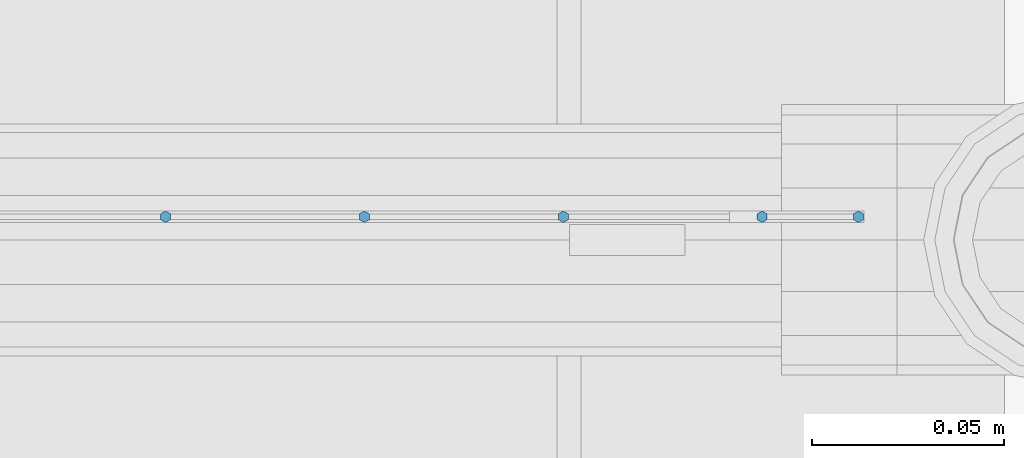
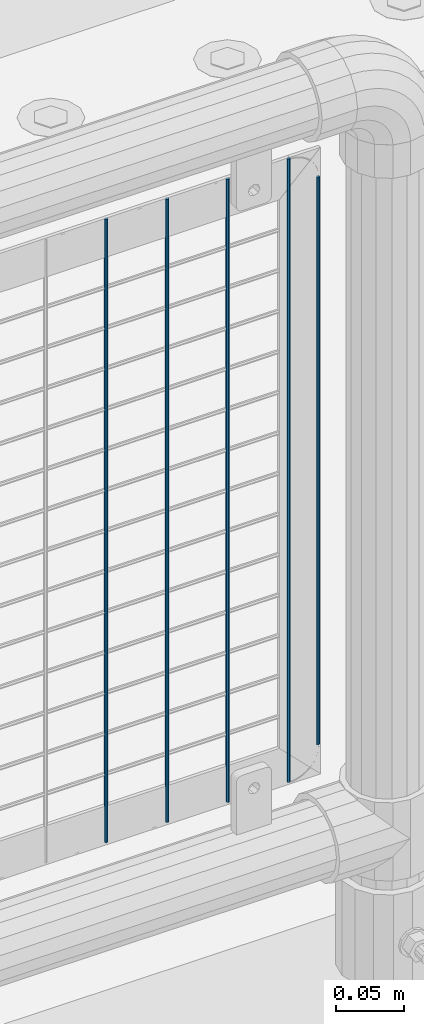
# One storey, part 80 of 193: 5 columns.
"""IFC2X3 building model written with IfcOpenShell, lengths in millimetres."""

from ifc_helpers import new_model, si_unit, frame, origin_with_axes, place, context, subcontext, project, spatial, faceted_brep, material, type_object, element, save


model = new_model("IFC2X3")

# Units and contexts
model_context = context("Model", 3, precision=1e-05, world=origin_with_axes())
body_context = subcontext(model_context, "Body", "Model", "MODEL_VIEW")
ifc_project = project(units=[si_unit("LENGTHUNIT", "METRE", prefix="MILLI"), si_unit("AREAUNIT", "SQUARE_METRE"), si_unit("VOLUMEUNIT", "CUBIC_METRE"), si_unit("MASSUNIT", "GRAM", prefix="KILO"), si_unit("TIMEUNIT", "SECOND"), si_unit("PLANEANGLEUNIT", "RADIAN"), si_unit("SOLIDANGLEUNIT", "STERADIAN"), si_unit("THERMODYNAMICTEMPERATUREUNIT", "DEGREE_CELSIUS"), si_unit("LUMINOUSINTENSITYUNIT", "LUMEN")], contexts=[model_context])

# Site, building, storey
site_placement = place(None, origin_with_axes())
site = spatial("IfcSite", under=ifc_project, at=site_placement, CompositionType="ELEMENT")
building_placement = place(site_placement, origin_with_axes())
building = spatial("IfcBuilding", under=site, at=building_placement, Name="Standard", CompositionType="ELEMENT")
storey_placement = place(building_placement, origin_with_axes())
storey = spatial("IfcBuildingStorey", under=building, at=storey_placement, Name="Undefined", CompositionType="ELEMENT", Elevation=0.0)

# Columns
ifc_material = material(Name="Misc_Undefined")
column_type = type_object("IfcColumnType", Name="D3", PredefinedType="NOTDEFINED")
for number, where, z_axis, x_axis in (
    (1, (-30354.66, 28670.5, 353.020000000001), (-1.0, 0.0, 0.0), (0.0, 0.0, 1.0)),
    (2, (-30406.315, 28670.5, 353.020000000001), (-1.0, 0.0, 0.0), (0.0, 0.0, 1.0)),
    (3, (-30457.97, 28670.5, 353.020000000001), (-1.0, 0.0, 0.0), (0.0, 0.0, 1.0)),
    (4, (-30303.005, 28670.5, 353.020000000001), (-1.0, 0.0, 0.0), (0.0, 0.0, 1.0)),
):
    element("IfcColumn", number, at=place(storey_placement, frame(where, z_axis=z_axis, x_axis=x_axis)), inside=storey, type_object=column_type, material=ifc_material, ObjectType="D3", context=body_context, shape_type="Brep", body=[
        faceted_brep([(0.0, -1.49999999999636, 3.63797880709171e-12), (0.0, -0.75, -1.29903810567669), (560.0, -0.75, -1.29903810567703), (560.0, -1.5, 0.0), (0.0, 0.75, -1.29903810567669), (560.0, 0.75, -1.29903810567703), (0.0, 1.50000000000364, 7.27595761418343e-12), (560.0, 1.5, 0.0), (0.0, 0.75, 1.29903810567669), (560.0, 0.75, 1.29903810567703), (0.0, -0.75, 1.29903810567669), (560.0, -0.75, 1.29903810567703)], [[[0, 1, 2, 3]], [[1, 4, 5, 2]], [[4, 6, 7, 5]], [[6, 8, 9, 7]], [[8, 10, 11, 9]], [[10, 0, 3, 11]], [[5, 7, 9, 11, 3, 2]], [[10, 8, 6, 4, 1, 0]]]),
    ])
column_placement = place(storey_placement, frame((-30278.0, 28670.5, 378.020000000001), z_axis=(-1.0, 0.0, 0.0), x_axis=(0.0, 0.0, 1.0)))
element("IfcColumn", 5, at=column_placement, inside=storey, type_object=column_type, material=ifc_material, ObjectType="D3", context=body_context, shape_type="Brep", body=[
    faceted_brep([(0.0, -1.49999999999636, 3.63797880709171e-12), (0.0, -0.75, -1.29903810567669), (510.0, -0.75, -1.29903810567703), (510.0, -1.5, 0.0), (0.0, 0.75, -1.29903810567669), (510.0, 0.75, -1.29903810567703), (0.0, 1.50000000000364, 7.27595761418343e-12), (510.0, 1.5, 0.0), (0.0, 0.75, 1.29903810567669), (510.0, 0.75, 1.29903810567703), (0.0, -0.75, 1.29903810567669), (510.0, -0.75, 1.29903810567703)], [[[0, 1, 2, 3]], [[1, 4, 5, 2]], [[4, 6, 7, 5]], [[6, 8, 9, 7]], [[8, 10, 11, 9]], [[10, 0, 3, 11]], [[5, 7, 9, 11, 3, 2]], [[10, 8, 6, 4, 1, 0]]]),
])

save(model, "model.ifc")
